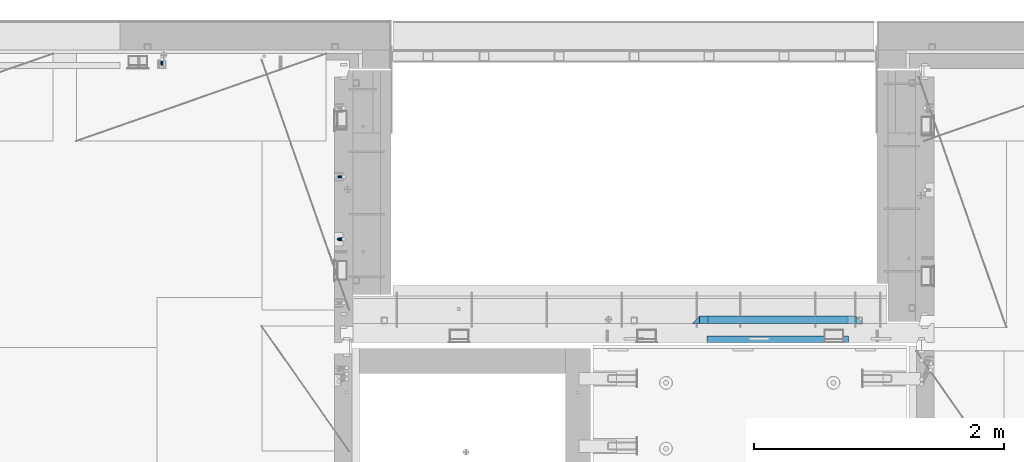
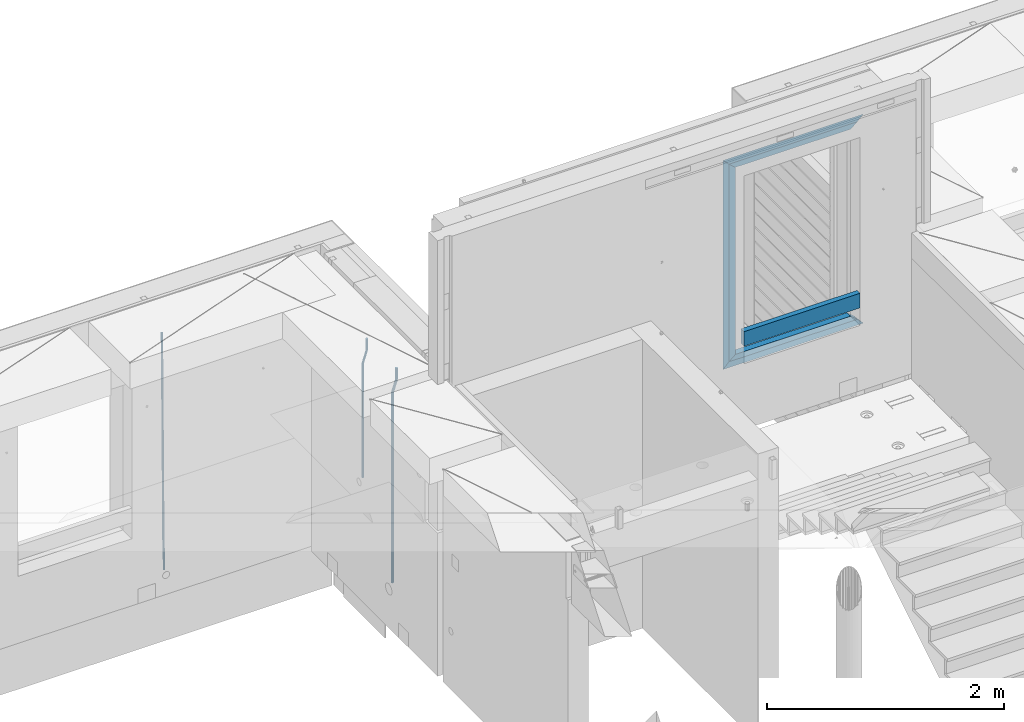
# One storey, part 123 of 350: 10 beams, 3 elements without a shape of their own.
"""IFC2X3 building model written with IfcOpenShell, lengths in millimetres."""

from ifc_helpers import new_model, si_unit, frame, origin_with_axes, place, context, subcontext, project, spatial, faceted_brep, material, type_object, element, aggregate, save


model = new_model("IFC2X3")

# Units and contexts
model_context = context("Model", 3, precision=1e-05, world=origin_with_axes())
body_context = subcontext(model_context, "Body", "Model", "MODEL_VIEW")
ifc_project = project(units=[si_unit("LENGTHUNIT", "METRE", prefix="MILLI"), si_unit("AREAUNIT", "SQUARE_METRE"), si_unit("VOLUMEUNIT", "CUBIC_METRE"), si_unit("MASSUNIT", "GRAM", prefix="KILO"), si_unit("TIMEUNIT", "SECOND"), si_unit("PLANEANGLEUNIT", "RADIAN"), si_unit("SOLIDANGLEUNIT", "STERADIAN"), si_unit("THERMODYNAMICTEMPERATUREUNIT", "DEGREE_CELSIUS"), si_unit("LUMINOUSINTENSITYUNIT", "LUMEN")], contexts=[model_context])

# Site, building, storey
site_placement = place(None, origin_with_axes())
site = spatial("IfcSite", under=ifc_project, at=site_placement, CompositionType="ELEMENT")
building_placement = place(site_placement, origin_with_axes())
building = spatial("IfcBuilding", under=site, at=building_placement, CompositionType="ELEMENT")
storey_placement = place(building_placement, origin_with_axes())
storey = spatial("IfcBuildingStorey", under=building, at=storey_placement, Name="2", CompositionType="ELEMENT", Elevation=0.0)

# Assembly, beam
assembly_1_placement = place(storey_placement, origin_with_axes())
assembly_1 = element("IfcElementAssembly", 1, at=assembly_1_placement, inside=storey, AssemblyPlace="NOTDEFINED", PredefinedType="REINFORCEMENT_UNIT")
ifc_material_1 = material()
beam_type_1 = type_object("IfcBeamType", Name="D20", PredefinedType="NOTDEFINED")
beam_1_placement = place(assembly_1_placement, frame((17685.0, 21755.0073333522, 87407.5), z_axis=(-0.999999913638316, 0.000415599999849952, 0.0), x_axis=(0.0, 0.0, -1.0)))
beam_1 = element("IfcBeam", 2, at=beam_1_placement, type_object=beam_type_1, material=ifc_material_1, Name="JM20", ObjectType="D20", context=body_context, shape_type="Brep", body=[
    faceted_brep([(0.0, -10.0, 0.0), (-4.19531716033816e-08, -7.07106781186667, -7.07106781187031), (113.248091332178, -7.0710684840451, -7.0710678117357), (113.248091314759, -10.0000006713562, -2.51020537689328e-10), (0.0, 0.0, -10.0), (113.248091374131, -6.72178430249915e-07, -9.99999999986903), (4.196772351861e-08, 7.07106781186303, -7.07106781186667), (113.248091416113, 7.07106713968824, -7.07106781173934), (0.0, 10.0, 0.0), (113.248091433488, 9.99999932782521, 1.30967237055302e-10), (4.196772351861e-08, 7.07106781185939, 7.07106781185939), (113.248091416113, 7.0710671396846, 7.071067811994), (0.0, 0.0, 10.0), (113.248091374131, -6.72174792271107e-07, 10.0000000001273), (-4.19531716033816e-08, -7.07106781187031, 7.07106781185939), (113.248091332178, -7.0710684840451, 7.071067811994), (130.699843527167, -7.06993249763036, -4.33745683788584), (128.538066582521, -9.99900540317321, 2.39499413731755), (131.594536475241, 0.00119355250353692, -7.12624594330919), (130.698046432328, 7.07220300913468, -4.33773834422391), (128.535525107087, 10.0009944322555, 2.39459602660281), (126.373748162892, 7.07192152754578, 9.1270470011732), (125.479055214906, 0.000795477419160306, 11.9158361066184), (126.37554525779, -7.07021397921199, 9.12732850753673), (240.336258550378, -7.05529970173666, 30.8729495437874), (238.174481606227, -9.98437260450009, 37.6054005176375), (241.230951498423, 0.0158263482953771, 28.0841604381058), (240.334461455612, 7.0868358050102, 30.8726680369582), (238.171940130502, 10.0156272283348, 37.6050024077231), (236.010163186409, 7.08655432384694, 44.3374533824244), (235.115470238379, 0.0154282738185429, 47.1262424881097), (236.011960281176, -7.05558118289991, 44.3377348892536), (253.461915329972, -7.05444528127919, 32.9289287376414), (253.46191532613, -9.98337746617108, 39.9999965521893), (253.461915339081, 0.0166225284556276, 29.9999965443676), (253.461915348205, 7.08769034247234, 32.9289287273205), (253.461915352003, 10.0166225357716, 39.9999965370152), (253.461915348293, 7.08769035281148, 47.0710643509774), (253.461915339183, 0.0166225430875784, 49.999996544273), (253.46191533003, -7.05444527093641, 47.0710643613093), (1417.49999998364, -7.05444797759628, 32.9289287358552), (1417.49999997689, -9.98338016170965, 39.9999965493844), (1417.49999999996, 0.0166198326005542, 29.9999965436982), (1417.50000001628, 7.08768764613342, 32.9289287278079), (1417.50000002306, 10.0166198382904, 39.9999965380084), (1417.5000000163, 7.08768765417699, 47.0710643515376), (1417.49999999999, 0.0166198439801519, 49.9999965436946), (1417.49999998366, -7.05444796955271, 47.0710643595849)], [[[0, 1, 2, 3]], [[1, 4, 5, 2]], [[4, 6, 7, 5]], [[6, 8, 9, 7]], [[8, 10, 11, 9]], [[10, 12, 13, 11]], [[12, 14, 15, 13]], [[14, 0, 3, 15]], [[14, 12, 10, 8, 6, 4, 1, 0]], [[3, 2, 16, 17]], [[2, 5, 18, 16]], [[5, 7, 19, 18]], [[7, 9, 20, 19]], [[9, 11, 21, 20]], [[11, 13, 22, 21]], [[13, 15, 23, 22]], [[15, 3, 17, 23]], [[17, 16, 24, 25]], [[16, 18, 26, 24]], [[18, 19, 27, 26]], [[19, 20, 28, 27]], [[20, 21, 29, 28]], [[21, 22, 30, 29]], [[22, 23, 31, 30]], [[23, 17, 25, 31]], [[25, 24, 32, 33]], [[24, 26, 34, 32]], [[26, 27, 35, 34]], [[27, 28, 36, 35]], [[28, 29, 37, 36]], [[29, 30, 38, 37]], [[30, 31, 39, 38]], [[31, 25, 33, 39]], [[33, 32, 40, 41]], [[32, 34, 42, 40]], [[34, 35, 43, 42]], [[35, 36, 44, 43]], [[36, 37, 45, 44]], [[37, 38, 46, 45]], [[38, 39, 47, 46]], [[39, 33, 41, 47]], [[42, 43, 44, 45, 46, 47, 41, 40]]]),
])

assembly_2_placement = place(storey_placement, origin_with_axes())
assembly_2 = element("IfcElementAssembly", 3, at=assembly_2_placement, inside=storey, AssemblyPlace="NOTDEFINED", PredefinedType="REINFORCEMENT_UNIT")
beam_2_placement = place(assembly_2_placement, frame((16230.0000000039, 22654.999995444, 84990.0), z_axis=(-0.000205762999925498, 0.999642804629538, -0.0267249099901004), x_axis=(4.30000201928125e-08, 0.0267249099948059, 0.999642825806181)))
beam_2 = element("IfcBeam", 4, at=beam_2_placement, type_object=beam_type_1, material=ifc_material_1, Name="JM20", ObjectType="D20", context=body_context, shape_type="Brep", body=[
    faceted_brep([(0.0, -10.0, 0.0), (-4.19531716033816e-08, -7.07106781186667, -7.07106781187031), (60.4266690400545, -7.0710677960451, -7.07106780570757), (60.4266690441291, -9.99999998418934, 6.15546014159918e-09), (0.0, 0.0, -10.0), (60.426669036824, 1.58106558956206e-08, -9.99999999384454), (4.196772351861e-08, 7.07106781186303, -7.07106781186667), (60.4266690363438, 7.07106782768096, -7.07106780570757), (0.0, 10.0, 0.0), (60.4266690388904, 10.0000000158179, 6.15182216279209e-09), (4.196772351861e-08, 7.07106781185939, 7.07106781185939), (60.4266690429649, 7.07106782768096, 7.07106781802577), (0.0, 0.0, 10.0), (60.4266690461809, 1.58179318532348e-08, 10.0000000061555), (-4.19531716033816e-08, -7.07106781187031, 7.07106781185939), (60.4266690466611, -7.07106779605238, 7.07106781802213), (61.0378400410118, -7.07106779588503, -7.07106780564936), (60.991799419251, -9.99999998403655, 6.21366780251265e-09), (61.0569027789461, 1.5985278878361e-08, -9.99999999378269), (61.0378209396877, 7.07106782784831, -7.07106780564936), (60.9917724058905, 10.0000000159635, 6.21366780251265e-09), (60.9457317841297, 7.07106782781193, 7.0710678180767), (60.9266690461809, 1.59488990902901e-08, 10.0000000062028), (60.9457508854539, -7.07106779591413, 7.0710678180767), (61.6489592143771, -7.07106614513759, -7.06310863441468), (61.5568818710308, -9.9999984576425, 0.00735959856683621), (61.6870830769039, 1.71821739058942e-06, -9.99179257185824), (61.6489210170112, 7.07106947854481, -7.06310888312146), (61.556827851804, 10.0000015422847, 0.00735924683976918), (61.4647505084577, 7.07106922979438, 7.07782747982128), (61.4266266459163, 1.36643211590126e-06, 10.0065114172685), (61.464788705809, -7.07106639389531, 7.07782772852806), (176.543135720174, -7.07075579406956, -5.56673531796696), (176.451058376813, -9.99968810657447, 1.50373291501455), (176.581259582701, 0.000312069292704109, -8.49541925541052), (176.543097522794, 7.07137982961285, -5.56673556667374), (176.451004357587, 10.00031189336, 1.50373256329476), (176.35892701424, 7.07137958085514, 8.57420079627263), (176.320803151699, 0.000311717507429421, 11.5028847337162), (176.358965211621, -7.07075604281999, 8.57420104497578), (177.098753836006, -7.07075429323595, -5.55949898843028), (176.98362511232, -9.99968666800123, 1.510669025065), (177.146421932586, 0.000313595905026887, -8.48805862247536), (177.098706077581, 7.07138133041735, -5.55949936166144), (176.983557571715, 10.0003133318824, 1.51066849724157), (176.868428848029, 7.07138095712435, 8.58083651073321), (176.820760751449, 0.000313067976094317, 11.5093961447819), (176.868476606425, -7.07075466652896, 8.58083688396073), (177.654312950661, -7.07075204110879, -5.54863964998367), (177.516135294456, -9.99968450931192, 1.52107783331303), (177.711524267797, 0.000315886711177882, -8.47701274570863), (177.654255632195, 7.07138358250813, -5.54864021007961), (177.516054233929, 10.0003154905207, 1.5210770412159), (177.377876577739, 7.0713830223176, 8.59079452451624), (177.320665260588, 0.000315094497636892, 11.5191676202448), (177.377933896176, -7.07075260129932, 8.59079508461218), (299.436796249574, -7.07025836271714, -3.1681962331204), (299.298618593355, -9.99919083092027, 3.90152125031091), (299.494007566798, 0.000809565110102994, -6.09656932889993), (299.436738931283, 7.07187726089978, -3.16819679320906), (299.298537533061, 10.0008091689197, 3.90152045822106), (299.160359876842, 7.07187670072017, 10.9712379416487), (299.103148559603, 0.000808772889286047, 13.8996110374392), (299.160417195119, -7.07025892290039, 10.9712385017483), (299.98743051647, -7.07025613056248, -3.15743315966392), (299.971788958996, -9.99918809853989, 3.91467979818117), (299.993912075952, 0.000811591617093654, -6.08679785393178), (299.987423933868, 7.07187949325817, -3.1574327280432), (299.971753863239, 10.0008119014747, 3.91467990454839), (299.95611230444, 7.07187992653053, 10.9867922621015), (299.949630744944, 0.000812204350950196, 13.9161569563694), (299.956118887014, -7.07025569729012, 10.9867918304735), (300.538107039494, -7.07025785017686, -3.16575821840888), (300.644985195438, -9.99919020432935, 3.90450175465594), (300.493854948218, 0.000810030429420294, -6.09435592770024), (300.538151196495, 7.071877773491, -3.16575855385963), (300.645047642858, 10.0008097955724, 3.90450128024895), (300.751925798773, 7.07187744142357, 10.9747612533101), (300.796177890064, 0.000809560813650023, 13.9033589625978), (300.751881641787, -7.07025818224065, 10.9747615887682), (2293.36490490142, -7.07648090940347, -33.2930642912361), (2293.47178305736, -10.0054132635523, -26.2228043181785), (2293.32065281013, -0.00541302880083094, -36.2216620005347), (2293.36494905842, 7.06565471425711, -33.2930646266868), (2293.47184550477, 9.99458673634581, -26.2228047925819), (2293.57872366071, 7.06565438219332, -19.1525448195243), (2293.62297575199, -0.00541349841296324, -16.2239471102366), (2293.57867950371, -7.0764812414709, -19.1525444840736), (2294.0658245362, -7.07648309818615, -33.3036607065333), (2294.05312277409, -10.0054150789219, -26.2315929392535), (2294.10928714235, -0.00541549149056664, -36.2335844756526), (2294.15805078732, 7.06565223761572, -33.3050546393533), (2294.18355038921, 9.99458451388637, -26.2335642579346), (2294.17084862708, 7.06565253314329, -19.1614964906439), (2294.12738602093, -0.00541507354500936, -16.2315727215355), (2294.07862237596, -7.07648280265857, -19.1601025578348), (2294.76670261032, -7.08562269121467, -33.294332712383), (2294.63442802057, -10.0129954178956, -26.2238563411993), (2294.89787471293, -0.0156988342423574, -36.2230891548279), (2294.95110548967, 7.05531064255774, -33.2944998654275), (2294.89521307347, 9.98530428734011, -26.2240927312887), (2294.76293848372, 7.0579315606592, -19.1536163601049), (2294.63176638114, -0.0119922963167483, -16.2248599176673), (2294.57853560438, -7.08300177311321, -19.1534492070678), (2316.52657204497, -7.36937582653991, -33.0047303660212), (2316.39429745522, -10.2967485532172, -25.9342539948302), (2316.65774414754, -0.299451969567599, -35.9334868084661), (2316.7109749243, 6.7715575072325, -33.0048975190657), (2316.65508250811, 9.70155115201487, -25.9344903849269), (2316.52280791836, 6.7741784253376, -18.8640140137468), (2316.39163581574, -0.295745431634714, -15.9352575713092), (2316.33840503903, -7.36675490843481, -18.863846860706), (2317.16202064224, -7.37766220584308, -32.9962731735213), (2317.05438744847, -10.3053562613532, -25.9254688497131), (2317.23607125619, -0.306993473008333, -35.925789846493), (2317.23316144495, 6.76474808850253, -32.9979477328052), (2317.15499573652, 9.6950321815566, -25.9278370341635), (2317.04736254275, 6.7673381260538, -18.8570327103698), (2316.97331192881, -0.303330606784584, -15.9275160373909), (2316.97622174003, -7.37507216829545, -18.8553581510787), (2317.79752306276, -7.37578610372293, -32.9880110666527), (2317.71453320107, -10.3033876998124, -25.9168792378296), (2317.81444760226, -0.305295583297266, -35.918287695793), (2317.75539265381, 6.76628640723357, -32.9911928173897), (2317.65495180529, 9.69652304524061, -25.9213789128698), (2317.5719619436, 6.76892144914746, -18.8502470840467), (2317.55503740412, -0.301569071270933, -15.9199704549137), (2317.61409235255, -7.3731510618054, -18.847065333317), (2417.8183084176, -7.07752398473531, -31.6906369377139), (2417.73531855589, -10.0051255808248, -24.6195051088798), (2417.83523295709, -0.007033464313281, -34.6209135668432), (2417.77617800863, 7.06454852621755, -31.6938186884508), (2417.67573716014, 9.99478516423187, -24.6240047839383), (2417.59274729842, 7.06718356813872, -17.5528729551006), (2417.57582275895, -0.00330695228694822, -14.6225963259749), (2417.6348777074, -7.07488894281778, -17.5496912043673)], [[[0, 1, 2, 3]], [[1, 4, 5, 2]], [[4, 6, 7, 5]], [[6, 8, 9, 7]], [[8, 10, 11, 9]], [[10, 12, 13, 11]], [[12, 14, 15, 13]], [[14, 0, 3, 15]], [[14, 12, 10, 8, 6, 4, 1, 0]], [[3, 2, 16, 17]], [[2, 5, 18, 16]], [[5, 7, 19, 18]], [[7, 9, 20, 19]], [[9, 11, 21, 20]], [[11, 13, 22, 21]], [[13, 15, 23, 22]], [[15, 3, 17, 23]], [[17, 16, 24, 25]], [[16, 18, 26, 24]], [[18, 19, 27, 26]], [[19, 20, 28, 27]], [[20, 21, 29, 28]], [[21, 22, 30, 29]], [[22, 23, 31, 30]], [[23, 17, 25, 31]], [[25, 24, 32, 33]], [[24, 26, 34, 32]], [[26, 27, 35, 34]], [[27, 28, 36, 35]], [[28, 29, 37, 36]], [[29, 30, 38, 37]], [[30, 31, 39, 38]], [[31, 25, 33, 39]], [[33, 32, 40, 41]], [[32, 34, 42, 40]], [[34, 35, 43, 42]], [[35, 36, 44, 43]], [[36, 37, 45, 44]], [[37, 38, 46, 45]], [[38, 39, 47, 46]], [[39, 33, 41, 47]], [[41, 40, 48, 49]], [[40, 42, 50, 48]], [[42, 43, 51, 50]], [[43, 44, 52, 51]], [[44, 45, 53, 52]], [[45, 46, 54, 53]], [[46, 47, 55, 54]], [[47, 41, 49, 55]], [[49, 48, 56, 57]], [[48, 50, 58, 56]], [[50, 51, 59, 58]], [[51, 52, 60, 59]], [[52, 53, 61, 60]], [[53, 54, 62, 61]], [[54, 55, 63, 62]], [[55, 49, 57, 63]], [[57, 56, 64, 65]], [[56, 58, 66, 64]], [[58, 59, 67, 66]], [[59, 60, 68, 67]], [[60, 61, 69, 68]], [[61, 62, 70, 69]], [[62, 63, 71, 70]], [[63, 57, 65, 71]], [[65, 64, 72, 73]], [[64, 66, 74, 72]], [[66, 67, 75, 74]], [[67, 68, 76, 75]], [[68, 69, 77, 76]], [[69, 70, 78, 77]], [[70, 71, 79, 78]], [[71, 65, 73, 79]], [[73, 72, 80, 81]], [[72, 74, 82, 80]], [[74, 75, 83, 82]], [[75, 76, 84, 83]], [[76, 77, 85, 84]], [[77, 78, 86, 85]], [[78, 79, 87, 86]], [[79, 73, 81, 87]], [[81, 80, 88, 89]], [[80, 82, 90, 88]], [[82, 83, 91, 90]], [[83, 84, 92, 91]], [[84, 85, 93, 92]], [[85, 86, 94, 93]], [[86, 87, 95, 94]], [[87, 81, 89, 95]], [[89, 88, 96, 97]], [[88, 90, 98, 96]], [[90, 91, 99, 98]], [[91, 92, 100, 99]], [[92, 93, 101, 100]], [[93, 94, 102, 101]], [[94, 95, 103, 102]], [[95, 89, 97, 103]], [[97, 96, 104, 105]], [[96, 98, 106, 104]], [[98, 99, 107, 106]], [[99, 100, 108, 107]], [[100, 101, 109, 108]], [[101, 102, 110, 109]], [[102, 103, 111, 110]], [[103, 97, 105, 111]], [[105, 104, 112, 113]], [[104, 106, 114, 112]], [[106, 107, 115, 114]], [[107, 108, 116, 115]], [[108, 109, 117, 116]], [[109, 110, 118, 117]], [[110, 111, 119, 118]], [[111, 105, 113, 119]], [[113, 112, 120, 121]], [[112, 114, 122, 120]], [[114, 115, 123, 122]], [[115, 116, 124, 123]], [[116, 117, 125, 124]], [[117, 118, 126, 125]], [[118, 119, 127, 126]], [[119, 113, 121, 127]], [[121, 120, 128, 129]], [[120, 122, 130, 128]], [[122, 123, 131, 130]], [[123, 124, 132, 131]], [[124, 125, 133, 132]], [[125, 126, 134, 133]], [[126, 127, 135, 134]], [[127, 121, 129, 135]], [[130, 131, 132, 133, 134, 135, 129, 128]]]),
])
aggregate(assembly_2, [beam_2])

# Beam
beam_type_2 = type_object("IfcBeamType", Name="D25", PredefinedType="NOTDEFINED")
beam_3_placement = place(assembly_1_placement, frame((17685.0, 21255.0073333522, 87407.5), z_axis=(-0.999999913638316, 0.000415599999849952, 0.0), x_axis=(0.0, 0.0, -1.0)))
beam_3 = element("IfcBeam", 5, at=beam_3_placement, type_object=beam_type_2, material=ifc_material_1, Name="JM25", ObjectType="D25", context=body_context, shape_type="Brep", body=[
    faceted_brep([(-7.41420080885291e-08, -12.5, -3.63797880709171e-12), (-6.42030499875546e-08, -10.8253175473074, -6.25000000000364), (113.248091310059, -10.8253182190492, -6.25000000001091), (113.248091299931, -12.5000006708469, -2.80124368146062e-10), (-3.70782800018787e-08, -6.25000000000364, -10.8253175473074), (113.248091337184, -6.25000067174187, -10.8253175473183), (-1.45519152283669e-11, -3.63797880709171e-12, -12.5), (113.248091374247, -6.71741872793064e-07, -12.5000000000109), (3.70637280866504e-08, 6.25, -10.8253175473074), (113.248091411326, 6.24999932825813, -10.8253175473183), (6.42030499875546e-08, 10.8253175473001, -6.25000000000364), (113.248091438465, 10.8253168755618, -6.25000000001091), (7.41420080885291e-08, 12.4999999999927, 0.0), (113.248091448404, 12.4999993282545, -1.09139364212751e-11), (6.42176019027829e-08, 10.8253175473001, 6.24999999999636), (113.24809143848, 10.8253168755618, 6.24999999998545), (3.70928319171071e-08, 6.24999999999636, 10.8253175473037), (113.248091411355, 6.24999932825449, 10.8253175472928), (1.45519152283669e-11, -3.63797880709171e-12, 12.4999999999964), (113.248091374277, -6.71741872793064e-07, 12.4999999999854), (-3.7049176171422e-08, -6.25000000000364, 10.8253175473001), (113.248091337213, -6.25000067174187, 10.8253175472928), (-6.41884980723262e-08, -10.8253175473074, 6.25), (113.248091310074, -10.8253182190492, 6.24999999998909), (130.449259230882, -10.8241986432586, -3.55564009493173), (128.538384125903, -12.4990054706068, 2.39504387892885), (131.847691315706, -6.24879007587151, -7.91190976778307), (132.358971633032, 0.00124320192480809, -9.50650619965018), (131.846103034666, 6.25120982069348, -7.91215856435883), (130.446508247391, 10.826436272193, -3.55607102324211), (128.535207564215, 12.5009943235709, 2.39454628487874), (126.624332459658, 10.8261874972886, 8.34523025788076), (125.225900374833, 6.25077892990521, 12.7014999307248), (124.714620057581, 0.000745652105251793, 14.2960963626065), (125.227488655888, -6.24922096664886, 12.7017487273151), (126.62708344312, -10.8244474181665, 8.3456611861875), (240.085674248156, -10.8095671496994, 31.6547662857156), (238.174799143511, -12.4843739739517, 37.6054502584157), (241.484106332937, -6.23415858247972, 27.2984966126423), (241.995386650233, 0.0158746952838555, 25.703900180506), (241.482518051911, 6.26584131414347, 27.2982478155536), (240.082923264708, 10.8410677658503, 31.6543353565175), (238.171622581605, 12.5156258174902, 37.6049526646493), (236.260747477107, 10.8408189914335, 43.5556366377568), (234.862315392325, 6.26541042421377, 47.9119063108337), (234.351035075029, 0.0153771464501915, 49.5065027429664), (234.863903673351, -6.23458947240579, 47.9121551079224), (236.263498460554, -10.8098159241163, 43.5560675669512), (253.461915305525, -10.8086965039183, 33.7499965486895), (253.461915300941, -12.4833789551158, 39.9999965501447), (253.461915317355, -6.23337895905206, 29.1746789989811), (253.461915333464, 0.0166210400311684, 27.4999965429452), (253.461915349588, 6.26662104088609, 29.1746789923018), (253.461915361389, 10.8419385905909, 33.7499965371353), (253.461915365653, 12.5166210465904, 39.9999965362076), (253.461915361288, 10.8419385972084, 46.2499965370662), (253.461915349428, 6.26662105234573, 50.8253140867819), (253.461915333304, 0.0166210532552213, 52.4999965428069), (253.461915317152, -6.23337894759607, 50.8253140934612), (253.461915305408, -10.8086964973008, 46.2499965486277), (2197.49999997206, -10.8087015173915, 33.749996548926), (2197.49999996777, -12.4833839668026, 39.9999965498064), (2197.49999998385, -6.23338397248881, 29.1746789992176), (2197.49999999997, 0.0166160266307998, 27.4999965432398), (2197.50000001608, 6.26661602751119, 29.1746789926474), (2197.5000000279, 10.8419335772196, 33.74999653755), (2197.5000000322, 12.5166160331937, 39.9999965366696), (2197.50000002791, 10.8419335837862, 46.2499965375537), (2197.50000001611, 6.26661603888351, 50.8253140872584), (2197.5, 0.0166160397602653, 52.4999965432398), (2197.49999998388, -6.23338396111649, 50.825314093825), (2197.49999997209, -10.8087015108249, 46.2499965489224)], [[[0, 1, 2, 3]], [[1, 4, 5, 2]], [[4, 6, 7, 5]], [[6, 8, 9, 7]], [[8, 10, 11, 9]], [[10, 12, 13, 11]], [[12, 14, 15, 13]], [[14, 16, 17, 15]], [[16, 18, 19, 17]], [[18, 20, 21, 19]], [[20, 22, 23, 21]], [[22, 0, 3, 23]], [[22, 20, 18, 16, 14, 12, 10, 8, 6, 4, 1, 0]], [[3, 2, 24, 25]], [[2, 5, 26, 24]], [[5, 7, 27, 26]], [[7, 9, 28, 27]], [[9, 11, 29, 28]], [[11, 13, 30, 29]], [[13, 15, 31, 30]], [[15, 17, 32, 31]], [[17, 19, 33, 32]], [[19, 21, 34, 33]], [[21, 23, 35, 34]], [[23, 3, 25, 35]], [[25, 24, 36, 37]], [[24, 26, 38, 36]], [[26, 27, 39, 38]], [[27, 28, 40, 39]], [[28, 29, 41, 40]], [[29, 30, 42, 41]], [[30, 31, 43, 42]], [[31, 32, 44, 43]], [[32, 33, 45, 44]], [[33, 34, 46, 45]], [[34, 35, 47, 46]], [[35, 25, 37, 47]], [[37, 36, 48, 49]], [[36, 38, 50, 48]], [[38, 39, 51, 50]], [[39, 40, 52, 51]], [[40, 41, 53, 52]], [[41, 42, 54, 53]], [[42, 43, 55, 54]], [[43, 44, 56, 55]], [[44, 45, 57, 56]], [[45, 46, 58, 57]], [[46, 47, 59, 58]], [[47, 37, 49, 59]], [[49, 48, 60, 61]], [[48, 50, 62, 60]], [[50, 51, 63, 62]], [[51, 52, 64, 63]], [[52, 53, 65, 64]], [[53, 54, 66, 65]], [[54, 55, 67, 66]], [[55, 56, 68, 67]], [[56, 57, 69, 68]], [[57, 58, 70, 69]], [[58, 59, 71, 70]], [[59, 49, 61, 71]], [[62, 63, 64, 65, 66, 67, 68, 69, 70, 71, 61, 60]]]),
])

aggregate(assembly_1, [beam_3, beam_1])

# Assembly, beams
assembly_3_placement = place(storey_placement, origin_with_axes())
assembly_3 = element("IfcElementAssembly", 6, at=assembly_3_placement, inside=storey, AssemblyPlace="NOTDEFINED", PredefinedType="REINFORCEMENT_UNIT")
ifc_material_2 = material(Name="TIMBER/T24")
beam_type_3 = type_object("IfcBeamType", PredefinedType="NOTDEFINED")
beam_4_placement = place(assembly_3_placement, frame((21724.9984049797, 20455.0, 87185.0), z_axis=(0.0, 0.0, 1.0), x_axis=(-1.0, 3.00000001838171e-08, 0.0)))
beam_4 = element("IfcBeam", 7, at=beam_4_placement, type_object=beam_type_3, material=ifc_material_2, context=body_context, shape_type="Brep", body=[
    faceted_brep([(-3.63797880709171e-12, 24.9999999999964, -75.0), (-3.63797880709171e-12, 24.9999999999964, 75.0), (1130.0, 25.0, 75.0), (1130.0, 25.0, -75.0), (0.0, -25.0000000000073, 75.0), (1130.0, -25.0, 75.0), (0.0, -25.0000000000073, -75.0), (1130.0, -25.0, -75.0)], [[[0, 1, 2, 3]], [[1, 4, 5, 2]], [[4, 6, 7, 5]], [[6, 0, 3, 7]], [[5, 7, 3, 2]], [[6, 4, 1, 0]]]),
])
ifc_material_3 = material(Name="CONCRETE/C25/30")
beam_type_4 = type_object("IfcBeamType", PredefinedType="NOTDEFINED")
beam_5_placement = place(assembly_3_placement, frame((21844.9984049797, 20610.0000000447, 88945.0), z_axis=(0.0, 0.0, -1.0), x_axis=(-1.0, 3.00000001838171e-08, 0.0)))
beam_5 = element("IfcBeam", 8, at=beam_5_placement, type_object=beam_type_4, material=ifc_material_3, context=body_context, shape_type="Brep", body=[
    faceted_brep([(1310.0, -30.0, 30.0), (60.0000000000073, -30.0, 30.0), (0.0, -30.0, -30.0), (1370.0, -30.0, -30.0), (1310.0, 30.0, 30.0), (60.0000000000073, 30.0, 30.0)], [[[0, 1, 2, 3]], [[0, 3, 4]], [[1, 0, 4, 5]], [[5, 2, 1]], [[4, 3, 2, 5]]]),
])
beam_6_placement = place(assembly_3_placement, frame((21784.9984049797, 20609.9999988829, 88885.0), z_axis=(0.0, 0.0, -1.0), x_axis=(-1.0, 3.00000001838171e-08, 0.0)))
beam_6 = element("IfcBeam", 9, at=beam_6_placement, type_object=beam_type_4, material=ifc_material_3, context=body_context, shape_type="Brep", body=[
    faceted_brep([(0.0, -30.0, -30.0), (64.0540540540533, -30.0, 24.9034748914419), (65.6756756756768, 30.0, 26.293436281092), (0.0, 30.0, -30.0), (64.0540540540533, -30.0, 24.0540540540533), (65.6756756756768, 30.0, 25.6756756756804), (1185.94594588314, -29.9999988381387, 24.0540541168593), (1184.32432432432, 29.9999988381387, 25.6756756756804), (1184.32432432432, 29.9999988381387, 26.2934362810629), (1250.0, 29.9999988381387, -30.0), (1250.0, -29.9999988381387, -30.0), (1185.94594588314, -29.9999988381387, 24.9034749452549)], [[[0, 1, 2, 3]], [[4, 5, 2, 1]], [[6, 7, 5, 4]], [[3, 2, 5, 7, 8, 9]], [[0, 3, 9, 10]], [[6, 4, 1, 0, 10, 11]], [[7, 6, 11, 8]], [[10, 9, 8, 11]]]),
])
beam_7_placement = place(assembly_3_placement, frame((20504.9984049797, 20610.0000000447, 88975.0), z_axis=(1.0, 0.0, 0.0), x_axis=(0.0, 0.0, -1.0)))
beam_7 = element("IfcBeam", 10, at=beam_7_placement, type_object=beam_type_4, material=ifc_material_3, context=body_context, shape_type="Brep", body=[
    faceted_brep([(60.0000000000073, 30.0, 30.0), (0.0, -30.0, -30.0), (60.0000000000073, -30.0, 30.0), (2095.00000000001, -30.0, 30.0), (2155.0, -30.0, -30.0), (2095.00000000001, 30.0, 30.0)], [[[0, 1, 2]], [[3, 2, 1, 4]], [[3, 4, 5]], [[2, 3, 5, 0]], [[4, 1, 0, 5]]]),
])
beam_8_placement = place(assembly_3_placement, frame((20534.9984049797, 20609.9999988829, 86910.0), z_axis=(0.0, 0.0, 1.0), x_axis=(1.0, 0.0, 0.0)))
beam_8 = element("IfcBeam", 11, at=beam_8_placement, type_object=beam_type_4, material=ifc_material_3, context=body_context, shape_type="Brep", body=[
    faceted_brep([(1185.94594588314, -29.9999988381387, 24.0540541168593), (1184.32432432432, 29.9999988381387, 25.6756756756804), (65.6756756756768, 30.0, 25.6756756756804), (64.0540540540533, -30.0, 24.0540540540533), (65.6756756756768, 30.0, 26.293436281092), (64.0540540540533, -30.0, 24.9034748914419), (0.0, -30.0, -30.0), (0.0, 30.0, -30.0), (1250.0, 29.9999988381387, -30.0), (1250.0, -29.9999988381387, -30.0), (1185.94594588314, -29.9999988381387, 24.9034749452549), (1184.32432432432, 29.9999988381387, 26.2934362810629)], [[[0, 1, 2, 3]], [[3, 2, 4, 5]], [[6, 5, 4, 7]], [[6, 7, 8, 9]], [[0, 3, 5, 6, 9, 10]], [[1, 0, 10, 11]], [[7, 4, 2, 1, 11, 8]], [[9, 8, 11, 10]]]),
])
beam_9_placement = place(assembly_3_placement, frame((20474.9984049797, 20610.0000000447, 86850.0), z_axis=(0.0, 0.0, 1.0), x_axis=(1.0, 0.0, 0.0)))
beam_9 = element("IfcBeam", 12, at=beam_9_placement, type_object=beam_type_4, material=ifc_material_3, context=body_context, shape_type="Brep", body=[
    faceted_brep([(60.0000000000073, 30.0, 30.0), (0.0, -30.0, -30.0), (60.0000000000073, -30.0, 30.0), (1310.0, -30.0, 30.0), (1370.0, -30.0, -30.0), (1310.0, 30.0, 30.0)], [[[0, 1, 2]], [[3, 2, 1, 4]], [[2, 3, 5, 0]], [[5, 4, 1, 0]], [[3, 4, 5]]]),
])
beam_type_5 = type_object("IfcBeamType", PredefinedType="NOTDEFINED")
beam_10_placement = place(assembly_3_placement, frame((20569.9984049797, 20609.9999988829, 88915.0), z_axis=(1.0, 0.0, 0.0), x_axis=(0.0, 0.0, -1.0)))
beam_10 = element("IfcBeam", 13, at=beam_10_placement, type_object=beam_type_5, material=ifc_material_3, context=body_context, shape_type="Brep", body=[
    faceted_brep([(2035.0, -29.9999988381387, -35.0), (2035.0, 29.9999988381387, -35.0), (1978.70656371892, 29.9999988381387, 30.6756756756731), (1980.09652505475, -29.9999988381387, 29.0540541168557), (56.2934362811066, 30.0, 30.6756756756768), (54.9034748914273, -30.0, 29.0540540540533), (0.0, -30.0, -35.0), (0.0, 30.0, -35.0)], [[[0, 1, 2, 3]], [[3, 2, 4, 5]], [[0, 3, 5, 6]], [[1, 0, 6, 7]], [[2, 1, 7, 4]], [[6, 5, 4, 7]]]),
])
aggregate(assembly_3, [beam_5, beam_6, beam_7, beam_10, beam_8, beam_4, beam_9])

save(model, "model.ifc")
